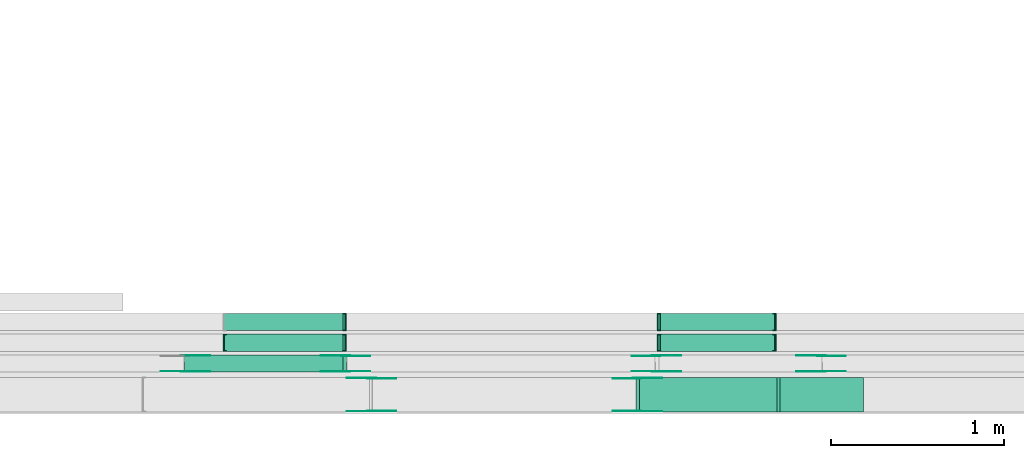
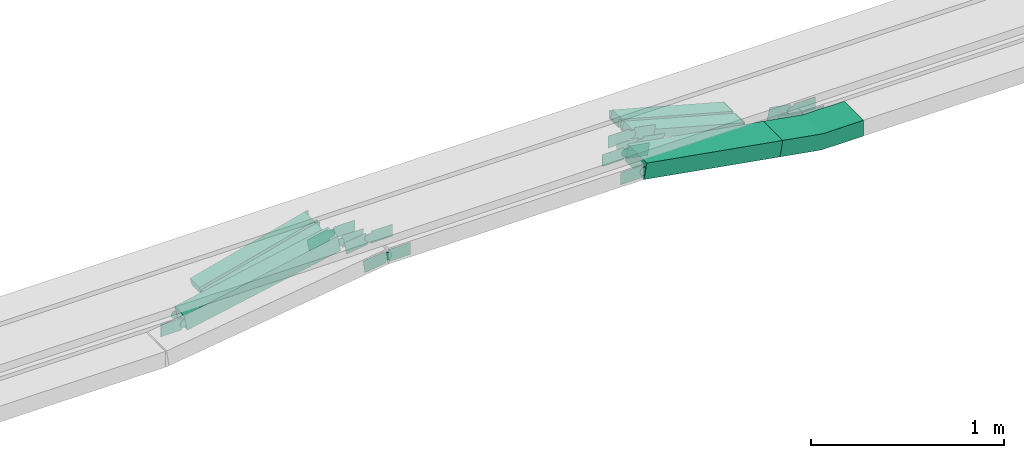
# One storey, part 8 of 31: 31 flow fittings, 6 flow segments.
"""IFC2X3 building model written with IfcOpenShell, lengths in millimetres."""

import ifcopenshell
import ifcopenshell.guid

model = None  # the IFC model being written
_history = None  # IfcOwnerHistory: only IFC2X3 demands one
_inside = {}  # id of a spatial element -> (the spatial element, [elements in it])
_under = {}  # id of a project, library or spatial element -> (it, [spatial elements below it])
_declared = {}  # id of a project -> (the project, [libraries it declares])
_typed = {}  # id of a type object -> (the type object, [elements of that type])
_made_of = {}  # id of a material, layer set ... -> (it, [elements and type objects made of it])


def new_model(schema):
    """Start an empty IFC model of exactly this schema.

    Asked for "IFC4X3", IfcOpenShell would pick the latest addendum, in which some entities
    have other attributes; the version numbers below select the first issue.
    IFC2X3 requires an IfcOwnerHistory on every rooted entity: one is made here for all.
    """
    global model, _history
    if schema == "IFC4X3":
        model = ifcopenshell.file(schema_version=(4, 3, 0, 0))
    else:
        model = ifcopenshell.file(schema=schema)
    _inside.clear()
    _under.clear()
    _declared.clear()
    _typed.clear()
    _made_of.clear()
    _history = None
    if model.schema == "IFC2X3":
        org = make("IfcOrganization", Name="unknown")
        user = make(
            "IfcPersonAndOrganization",
            ThePerson=make("IfcPerson", FamilyName="unknown"),
            TheOrganization=org,
        )
        app = make(
            "IfcApplication",
            ApplicationDeveloper=org,
            Version="unknown",
            ApplicationFullName="unknown",
            ApplicationIdentifier="unknown",
        )
        _history = make(
            "IfcOwnerHistory",
            OwningUser=user,
            OwningApplication=app,
            ChangeAction="ADDED",
            CreationDate=0,
        )
    return model


def make(cls, **values):
    """One entity of the class cls with the attributes given. An attribute that is None is left unset."""
    return model.create_entity(
        cls, **{name: value for name, value in values.items() if value is not None}
    )


def entity(cls, *values):
    """Any entity or typed value of the class cls, its attributes in the order of the schema. None: left unset."""
    e = model.create_entity(cls)
    for i, value in enumerate(values):
        if value is not None:
            e[i] = value
    return e


def rooted(cls, **values):
    """An entity with a GlobalId (a new one), such as an element, a storey or a relation."""
    return make(cls, GlobalId=ifcopenshell.guid.new(), OwnerHistory=_history, **values)


def si_unit(unit_type, name, prefix=None):
    """IfcSIUnit, for example si_unit("LENGTHUNIT", "METRE", prefix="MILLI")."""
    return make("IfcSIUnit", UnitType=unit_type, Prefix=prefix, Name=name)


def converted_unit(unit_type, name, factor, base, dimensions=None, offset=None):
    """IfcConversionBasedUnit, such as the inch: factor (a typed value) times the base unit."""
    return make(
        "IfcConversionBasedUnit"
        if offset is None
        else "IfcConversionBasedUnitWithOffset",
        ConversionOffset=offset,
        Dimensions=None
        if dimensions is None
        else entity("IfcDimensionalExponents", *dimensions),
        UnitType=unit_type,
        Name=name,
        ConversionFactor=make(
            "IfcMeasureWithUnit", ValueComponent=factor, UnitComponent=base
        ),
    )


def derived_unit(unit_type, elements):
    """IfcDerivedUnit: a product of units, each with its exponent."""
    return make(
        "IfcDerivedUnit",
        Elements=[
            make("IfcDerivedUnitElement", Unit=unit, Exponent=power)
            for unit, power in elements
        ],
        UnitType=unit_type,
    )


def assignment(units):
    """IfcUnitAssignment: the units of a project."""
    return None if units is None else make("IfcUnitAssignment", Units=units)


def point(xyz):
    """IfcCartesianPoint."""
    return None if xyz is None else make("IfcCartesianPoint", Coordinates=xyz)


def direction(xyz):
    """IfcDirection."""
    return None if xyz is None else make("IfcDirection", DirectionRatios=xyz)


def frame(location, z_axis=None, x_axis=None):
    """IfcAxis2Placement3D, a coordinate frame: its origin and axes. An axis left out is left unset."""
    return make(
        "IfcAxis2Placement3D",
        Location=point(location),
        Axis=direction(z_axis),
        RefDirection=direction(x_axis),
    )


def frame_2d(location, x_axis=None):
    """IfcAxis2Placement2D, a coordinate frame in the plane: its origin and x axis."""
    return make(
        "IfcAxis2Placement2D", Location=point(location), RefDirection=direction(x_axis)
    )


def origin():
    """The frame at (0, 0, 0) with its axes left unset."""
    return frame((0.0, 0.0, 0.0))


def origin_2d_with_axis():
    """The frame at (0, 0) in the plane with the x axis (1, 0) written out."""
    return frame_2d((0.0, 0.0), x_axis=(1.0, 0.0))


def place(relative_to, where):
    """IfcLocalPlacement: puts the frame where relative to a parent placement (None: the world)."""
    return make(
        "IfcLocalPlacement", PlacementRelTo=relative_to, RelativePlacement=where
    )


def context(
    kind, dimensions, precision=None, world=None, true_north=None, identifier=None
):
    """IfcGeometricRepresentationContext, for example the 3D "Model" context."""
    return make(
        "IfcGeometricRepresentationContext",
        ContextIdentifier=identifier,
        ContextType=kind,
        CoordinateSpaceDimension=dimensions,
        Precision=precision,
        WorldCoordinateSystem=world,
        TrueNorth=true_north,
    )


def subcontext(parent, identifier, kind, view, scale=None):
    """IfcGeometricRepresentationSubContext, for example "Body" below "Model"."""
    return make(
        "IfcGeometricRepresentationSubContext",
        ContextIdentifier=identifier,
        ContextType=kind,
        ParentContext=parent,
        TargetScale=scale,
        TargetView=view,
    )


def project(units=None, contexts=None):
    """IfcProject with its units and contexts."""
    return rooted(
        "IfcProject",
        Name="project",
        RepresentationContexts=contexts,
        UnitsInContext=assignment(units),
    )


def spatial(cls, under=None, at=None, **own):
    """A site, building, storey or space (cls), placed at a placement, below another one or the project."""
    s = rooted(cls, ObjectPlacement=at, **own)
    if under is not None:
        _under.setdefault(under.id(), (under, []))[1].append(s)
    return s


def polyline(points):
    """IfcPolyline through the points."""
    return make("IfcPolyline", Points=[point(p) for p in points])


def circle_curve(where, radius):
    """IfcCircle in the frame where."""
    return make("IfcCircle", Position=where, Radius=radius)


def parameter(value):
    """IfcParameterValue: where a trimmed curve begins or ends, as a parameter of its basis curve."""
    return model.create_entity("IfcParameterValue", value)


def trimmed(basis, trim1, trim2, sense, master):
    """IfcTrimmedCurve: the piece of a basis curve between two trims."""
    return make(
        "IfcTrimmedCurve",
        BasisCurve=basis,
        Trim1=trim1,
        Trim2=trim2,
        SenseAgreement=sense,
        MasterRepresentation=master,
    )


def segment(curve, same_sense, transition):
    """IfcCompositeCurveSegment."""
    return make(
        "IfcCompositeCurveSegment",
        Transition=transition,
        SameSense=same_sense,
        ParentCurve=curve,
    )


def composite_curve(segments, self_intersect=None):
    """IfcCompositeCurve: segments joined end to end."""
    return make("IfcCompositeCurve", Segments=segments, SelfIntersect=self_intersect)


def profile(cls, at=None, kind="AREA", **sizes):
    """A parametric profile (cls). Its sizes go by their IFC names, for example OverallWidth=200.0."""
    return make(cls, ProfileType=kind, Position=at, **sizes)


def rectangle(**sizes):
    """IfcRectangleProfileDef."""
    return profile("IfcRectangleProfileDef", **sizes)


def outline(outer, holes=None, kind="AREA"):
    """IfcArbitraryClosedProfileDef: a profile drawn as a closed curve; with holes, ...WithVoids."""
    if holes is None:
        return make("IfcArbitraryClosedProfileDef", ProfileType=kind, OuterCurve=outer)
    return make(
        "IfcArbitraryProfileDefWithVoids",
        ProfileType=kind,
        OuterCurve=outer,
        InnerCurves=holes,
    )


def extrude(swept, where, along, depth):
    """IfcExtrudedAreaSolid: the profile swept, set in the frame where, extruded along a direction by depth."""
    return make(
        "IfcExtrudedAreaSolid",
        SweptArea=swept,
        Position=where,
        ExtrudedDirection=direction(along),
        Depth=depth,
    )


def faces_of(points, faces, orient=None, outer=None):
    """IfcFace entities. A face is a list of loops; a loop is a list of indices into points, from 0.

    orient and outer hold one flag for each loop. By default every Orientation is true, the
    first loop of a face is its IfcFaceOuterBound and the others are IfcFaceBound.
    """
    made = []
    for i, loops in enumerate(faces):
        bounds = []
        for j, loop in enumerate(loops):
            is_outer = j == 0 if outer is None else outer[i][j]
            bounds.append(
                make(
                    "IfcFaceOuterBound" if is_outer else "IfcFaceBound",
                    Bound=make("IfcPolyLoop", Polygon=[points[k] for k in loop]),
                    Orientation=True if orient is None else orient[i][j],
                )
            )
        made.append(make("IfcFace", Bounds=bounds))
    return made


def faceted_brep(points, faces, orient=None, outer=None, voids=None):
    """IfcFacetedBrep: a solid bounded by flat faces; with voids (closed shells), ...WithVoids."""
    shared = [point(p) for p in points]
    hull = make("IfcClosedShell", CfsFaces=faces_of(shared, faces, orient, outer))
    if voids is None:
        return make("IfcFacetedBrep", Outer=hull)
    return make(
        "IfcFacetedBrepWithVoids",
        Outer=hull,
        Voids=[
            make(cls, CfsFaces=faces_of(shared, fs, o, b)) for cls, fs, o, b in voids
        ],
    )


def shape(context_of_items, identifier, shape_type, items):
    """IfcShapeRepresentation: the items that make up one representation, for example the "Body"."""
    return make(
        "IfcShapeRepresentation",
        ContextOfItems=context_of_items,
        RepresentationIdentifier=identifier,
        RepresentationType=shape_type,
        Items=items,
    )


def source(mapping_origin, context_of_items, identifier, shape_type, items):
    """IfcRepresentationMap: a shape defined once, which mapped items show again and again."""
    return make(
        "IfcRepresentationMap",
        MappingOrigin=mapping_origin,
        MappedRepresentation=shape(context_of_items, identifier, shape_type, items),
    )


def transform(
    local_origin,
    x_axis=None,
    y_axis=None,
    z_axis=None,
    scale=None,
    scale2=None,
    scale3=None,
    uniform=True,
):
    """IfcCartesianTransformationOperator3D, or its non-uniform kind. x_axis, y_axis, z_axis: its Axis1, 2, 3."""
    if uniform:
        return make(
            "IfcCartesianTransformationOperator3D",
            Axis1=direction(x_axis),
            Axis2=direction(y_axis),
            LocalOrigin=point(local_origin),
            Scale=scale,
            Axis3=direction(z_axis),
        )
    return make(
        "IfcCartesianTransformationOperator3DnonUniform",
        Axis1=direction(x_axis),
        Axis2=direction(y_axis),
        LocalOrigin=point(local_origin),
        Scale=scale,
        Axis3=direction(z_axis),
        Scale2=scale2,
        Scale3=scale3,
    )


def mapped(mapping_source, mapping_target):
    """IfcMappedItem: shows the shape of a source again, moved by a transform."""
    return make(
        "IfcMappedItem", MappingSource=mapping_source, MappingTarget=mapping_target
    )


def material(Name=None, Category=None):
    """IfcMaterial."""
    return make("IfcMaterial", Name=Name, Category=Category)


def made_of(thing, what):
    """Note that an element or type object is made of a material, layer set ...; save() writes the relation."""
    if what is not None:
        _made_of.setdefault(what.id(), (what, []))[1].append(thing)
    return thing


def type_object(cls, material=None, **own):
    """A type object (cls), such as IfcWallType, which elements share."""
    return made_of(rooted(cls, **own), material)


def type_shapes(of_type, sources):
    """Give a type object the sources (RepresentationMaps) that its elements show as mapped items."""
    of_type.RepresentationMaps = sources


def element(
    cls,
    number,
    at=None,
    inside=None,
    cuts=None,
    type_object=None,
    material=None,
    context=None,
    identifier="Body",
    shape_type=None,
    held_by="IfcProductDefinitionShape",
    body=None,
    shapes=None,
    **own,
):
    """One element of the class cls, such as IfcWall. Its Tag is "e" and its number.

    at: its placement. inside: the storey or other place that contains it. cuts: it is an
    opening in that element (IfcRelVoidsElement). A single representation is given by context,
    identifier, shape_type and body (its items); several are given by shapes. held_by: the class
    of the entity that holds the representations. save() writes the other relations.
    """
    e = rooted(cls, Tag="e%d" % number, ObjectPlacement=at, **own)
    if body is not None:
        shapes = [shape(context, identifier, shape_type, body)]
    if shapes is not None:
        e.Representation = make(held_by, Representations=shapes)
    if inside is not None:
        _inside.setdefault(inside.id(), (inside, []))[1].append(e)
    if cuts is not None:
        rooted(
            "IfcRelVoidsElement", RelatingBuildingElement=cuts, RelatedOpeningElement=e
        )
    if type_object is not None:
        _typed.setdefault(type_object.id(), (type_object, []))[1].append(e)
    return made_of(e, material)


def aggregate(whole, parts):
    """IfcRelAggregates: a whole, such as a stair, and the parts it consists of."""
    return rooted("IfcRelAggregates", RelatingObject=whole, RelatedObjects=parts)


def save(model, path):
    """Write the relations noted so far, then the file.

    IfcRelAggregates (storeys below a building ...), IfcRelContainedInSpatialStructure (elements
    in a storey), IfcRelDefinesByType, IfcRelAssociatesMaterial and IfcRelDeclares: one each for
    every whole, place, type object, material and project.
    """
    for whole, parts in _under.values():
        aggregate(whole, parts)
    for where, things in _inside.values():
        rooted(
            "IfcRelContainedInSpatialStructure",
            RelatedElements=things,
            RelatingStructure=where,
        )
    for kind, things in _typed.values():
        rooted("IfcRelDefinesByType", RelatedObjects=things, RelatingType=kind)
    for what, things in _made_of.values():
        rooted("IfcRelAssociatesMaterial", RelatedObjects=things, RelatingMaterial=what)
    for by, libraries in _declared.values():
        rooted("IfcRelDeclares", RelatingContext=by, RelatedDefinitions=libraries)
    model.write(path)


model = new_model("IFC2X3")

# Units and contexts
model_context = context("Model", 3, precision=0.01, world=origin(), true_north=direction((6.12303176911189e-17, 1.0)))
body_context = subcontext(model_context, "Body", "Model", "MODEL_VIEW")
ifc_project = project(units=[si_unit("LENGTHUNIT", "METRE", prefix="MILLI"), si_unit("AREAUNIT", "SQUARE_METRE"), si_unit("VOLUMEUNIT", "CUBIC_METRE"), converted_unit("PLANEANGLEUNIT", "DEGREE", entity("IfcRatioMeasure", 0.0174532925199433), si_unit("PLANEANGLEUNIT", "RADIAN"), dimensions=[0, 0, 0, 0, 0, 0, 0]), si_unit("MASSUNIT", "GRAM", prefix="KILO"), derived_unit("MASSDENSITYUNIT", [(si_unit("MASSUNIT", "GRAM", prefix="KILO"), 1), (si_unit("LENGTHUNIT", "METRE"), -3)]), derived_unit("MOMENTOFINERTIAUNIT", [(si_unit("LENGTHUNIT", "METRE"), 4)]), si_unit("TIMEUNIT", "SECOND"), si_unit("FREQUENCYUNIT", "HERTZ"), si_unit("THERMODYNAMICTEMPERATUREUNIT", "DEGREE_CELSIUS"), derived_unit("THERMALTRANSMITTANCEUNIT", [(si_unit("MASSUNIT", "GRAM", prefix="KILO"), 1), (si_unit("THERMODYNAMICTEMPERATUREUNIT", "KELVIN"), -1), (si_unit("TIMEUNIT", "SECOND"), -3)]), derived_unit("VOLUMETRICFLOWRATEUNIT", [(si_unit("LENGTHUNIT", "METRE"), 3), (si_unit("TIMEUNIT", "SECOND"), -1)]), derived_unit("MASSFLOWRATEUNIT", [(si_unit("MASSUNIT", "GRAM", prefix="KILO"), 1), (si_unit("TIMEUNIT", "SECOND"), -1)]), derived_unit("ROTATIONALFREQUENCYUNIT", [(si_unit("TIMEUNIT", "SECOND"), -1)]), si_unit("ELECTRICCURRENTUNIT", "AMPERE"), si_unit("ELECTRICVOLTAGEUNIT", "VOLT"), si_unit("POWERUNIT", "WATT"), si_unit("FORCEUNIT", "NEWTON", prefix="KILO"), si_unit("ILLUMINANCEUNIT", "LUX"), si_unit("LUMINOUSFLUXUNIT", "LUMEN"), si_unit("LUMINOUSINTENSITYUNIT", "CANDELA"), derived_unit("USERDEFINED", [(si_unit("MASSUNIT", "GRAM", prefix="KILO"), -1), (si_unit("LENGTHUNIT", "METRE"), -2), (si_unit("TIMEUNIT", "SECOND"), 3), (si_unit("LUMINOUSFLUXUNIT", "LUMEN"), 1)]), derived_unit("LINEARVELOCITYUNIT", [(si_unit("LENGTHUNIT", "METRE"), 1), (si_unit("TIMEUNIT", "SECOND"), -1)]), si_unit("PRESSUREUNIT", "PASCAL"), derived_unit("USERDEFINED", [(si_unit("LENGTHUNIT", "METRE"), -2), (si_unit("MASSUNIT", "GRAM", prefix="KILO"), 1), (si_unit("TIMEUNIT", "SECOND"), -2)]), derived_unit("LINEARFORCEUNIT", [(si_unit("MASSUNIT", "GRAM", prefix="KILO"), 1), (si_unit("LENGTHUNIT", "METRE"), 1), (si_unit("TIMEUNIT", "SECOND"), -2), (si_unit("LENGTHUNIT", "METRE"), -1)]), derived_unit("PLANARFORCEUNIT", [(si_unit("MASSUNIT", "GRAM", prefix="KILO"), 1), (si_unit("LENGTHUNIT", "METRE"), 1), (si_unit("TIMEUNIT", "SECOND"), -2), (si_unit("LENGTHUNIT", "METRE"), -2)])], contexts=[model_context])

# Site, building, storey
site_placement = place(None, frame((0.0, -0.00077364408347762, 0.0)))
site = spatial("IfcSite", under=ifc_project, at=site_placement, CompositionType="ELEMENT")
building_placement = place(site_placement, origin())
building = spatial("IfcBuilding", under=site, at=building_placement, CompositionType="ELEMENT")
storey_placement = place(building_placement, frame((0.0, 0.0, 15900.0)))
storey = spatial("IfcBuildingStorey", under=building, at=storey_placement, CompositionType="ELEMENT", Elevation=15900.0)

# Flow segments
cable_carrier_segment_type = type_object("IfcCableCarrierSegmentType", PredefinedType="CABLETRAYSEGMENT")
flow_segment_1_placement = place(storey_placement, frame((23818.3797769775, 8695.50215480076, 2502.48100991724)))
element("IfcFlowSegment", 1, at=flow_segment_1_placement, inside=storey, type_object=cable_carrier_segment_type, context=body_context, shape_type="SweptSolid", body=[
    extrude(rectangle(XDim=50.0000000000003, YDim=99.9999999999989, at=origin_2d_with_axis()), frame((6.37700798333242, 50.0, 24.172996694259), z_axis=(0.966919867770266, 0.0, 0.255080319333208), x_axis=(-0.255080319333208, 0.0, 0.966919867770266)), (0.0, 0.0, 1.0), 712.293238662787),
])
flow_segment_2_placement = place(storey_placement, frame((26335.7437232467, 8695.50215480076, 2502.66588279373)))
element("IfcFlowSegment", 2, at=flow_segment_2_placement, inside=storey, type_object=cable_carrier_segment_type, context=body_context, shape_type="SweptSolid", body=[
    extrude(rectangle(XDim=50.0000000000012, YDim=99.9999999999989, at=frame_2d((0.0, 2.08899564313469e-12), x_axis=(0.0, 1.0))), frame((6.60618807540411, 50.0, 205.556862010423), z_axis=(0.964454896083655, 0.0, -0.264247523016331), x_axis=(0.0, 1.0, 0.0)), (0.0, 0.0, 1.0), 686.649727260089),
])
flow_segment_3_placement = place(storey_placement, frame((23587.5004149848, 8454.96624585791, 2502.1837733382)))
element("IfcFlowSegment", 3, at=flow_segment_3_placement, inside=storey, type_object=cable_carrier_segment_type, context=body_context, shape_type="SweptSolid", body=[
    extrude(rectangle(XDim=100.000000000002, YDim=100.000000000001, at=frame_2d((0.0, 1.08357767203415e-12), x_axis=(1.0, 0.0))), frame((9.7322474506551, 50.0, 49.0436882744265), z_axis=(0.980873765488559, 0.0, 0.194644949013056), x_axis=(-0.194644949013056, 0.0, 0.980873765488559)), (0.0, 0.0, 1.0), 937.836186864069),
])
flow_segment_4_placement = place(storey_placement, frame((23818.3797769775, 8575.50215480076, 2502.48100991724)))
element("IfcFlowSegment", 4, at=flow_segment_4_placement, inside=storey, type_object=cable_carrier_segment_type, context=body_context, shape_type="SweptSolid", body=[
    extrude(rectangle(XDim=50.0000000000003, YDim=100.000000000001, at=origin_2d_with_axis()), frame((6.37700798333242, 50.0, 24.172996694259), z_axis=(0.966919867770266, 0.0, 0.255080319333208), x_axis=(-0.255080319333208, 0.0, 0.966919867770266)), (0.0, 0.0, 1.0), 712.293238662787),
])
flow_segment_5_placement = place(storey_placement, frame((26335.7437232467, 8575.50215480076, 2502.66588279373)))
element("IfcFlowSegment", 5, at=flow_segment_5_placement, inside=storey, type_object=cable_carrier_segment_type, context=body_context, shape_type="SweptSolid", body=[
    extrude(rectangle(XDim=50.0000000000012, YDim=100.000000000001, at=frame_2d((0.0, 2.08899564313469e-12), x_axis=(0.0, 1.0))), frame((6.60618807540411, 50.0, 205.556862010419), z_axis=(0.964454896083655, 0.0, -0.264247523016331), x_axis=(0.0, 1.0, 0.0)), (0.0, 0.0, 1.0), 686.649727260089),
])
flow_segment_6_placement = place(storey_placement, frame((26209.4701647969, 8224.96624585793, 2543.15198452124)))
element("IfcFlowSegment", 6, at=flow_segment_6_placement, inside=storey, type_object=cable_carrier_segment_type, context=body_context, shape_type="SweptSolid", body=[
    extrude(rectangle(XDim=100.000000000002, YDim=200.0, at=origin_2d_with_axis()), frame((8.56658973083937, 100.0, 190.878206533637), z_axis=(0.985213386101388, 0.0, -0.171331794616871), x_axis=(0.171331794616871, 0.0, 0.985213386101388)), (0.0, 0.0, 1.0), 826.568924613313),
])

# Flow fittings
ifc_material_1 = material()
cable_carrier_fitting_type_1 = type_object("IfcCableCarrierFittingType", PredefinedType="NOTDEFINED", material=ifc_material_1)
shared_shape_1 = source(origin(), body_context, "Body", "Brep", [
    faceted_brep([(-6.4842580400182, 25.0, 50.0), (-6.4842580400182, 25.0, -50.0), (-6.48425804001836, -25.0, -50.0), (-6.48425804001836, -25.0, -47.4600000101565), (-6.48425804001821, 22.46000001016, -47.4600000101565), (-6.48425804001821, 22.46000001016, 47.4600000101635), (-6.48425804001836, -25.0, 47.4600000101635), (-6.48425804001836, -25.0, 50.0), (-0.107250056687216, 25.8270033057431, 50.0), (12.6467659099747, -22.5189900827698, 50.0), (12.6467659099747, -22.5189900827698, 47.4600000101635), (0.540653951827591, 23.3710268514305, 47.4600000101635), (0.54065395182759, 23.3710268514305, -47.4600000101565), (12.6467659099747, -22.5189900827698, -47.4600000101565), (12.6467659099747, -22.5189900827698, -50.0), (-0.107250056687218, 25.8270033057431, -50.0), (-3.24212902000882, 25.0, 50.0), (-3.24212902000888, 25.0, -50.0), (3.24212902000979, -25.0, -50.0), (3.24212902000979, -25.0, -47.4600000101565), (-2.91272871289353, 22.46000001016, -47.4600000101565), (-2.91272871289353, 22.46000001016, 47.4600000101635), (3.24212902000979, -25.0, 47.4600000101635), (3.24212902000979, -25.0, 50.0)], [[[0, 1, 2, 3, 4, 5, 6, 7]], [[8, 9, 10, 11, 12, 13, 14, 15]], [[1, 0, 16, 17]], [[2, 1, 17, 15, 14, 18]], [[3, 2, 18, 19]], [[4, 3, 19, 13, 12, 20]], [[5, 4, 20, 21]], [[6, 5, 21, 11, 10, 22]], [[7, 6, 22, 23]], [[0, 7, 23, 9, 8, 16]], [[17, 16, 8, 15]], [[19, 18, 14, 13]], [[21, 20, 12, 11]], [[23, 22, 10, 9]]]),
])
type_shapes(cable_carrier_fitting_type_1, [shared_shape_1])
for number, where, z_axis, x_axis in (
    (7, (24519.757027029, 8745.50215480077, 2710.0), (0.0, -1.0, 0.0), (-1.0, 0.0, 0.0)),
    (8, (24519.757027029, 8625.50215480077, 2710.0), (0.0, -1.0, 0.0), (-1.0, 0.0, 0.0)),
    (9, (23818.4870270342, 8625.50215480077, 2525.0), (0.0, 1.0, 0.0), (-0.966919867770264, 0.0, -0.255080319333216)),
):
    element("IfcFlowFitting", number, at=place(storey_placement, frame(where, z_axis=z_axis, x_axis=x_axis)), inside=storey, type_object=cable_carrier_fitting_type_1, material=ifc_material_1, context=body_context, shape_type="MappedRepresentation", body=[
        mapped(shared_shape_1, transform((0.0, 0.0, 0.0), scale=1.0)),
    ])
cable_carrier_fitting_type_2 = type_object("IfcCableCarrierFittingType", PredefinedType="NOTDEFINED", material=ifc_material_1)
shared_shape_2 = source(origin(), body_context, "Body", "Brep", [
    faceted_brep([(-6.7257213067909, 25.0, 50.0), (-6.7257213067909, 25.0, -50.0), (-6.72572130679106, -25.0, -50.0), (-6.72572130679106, -25.0, -47.4600000101565), (-6.7257213067909, 22.46000001016, -47.4600000101565), (-6.7257213067909, 22.46000001016, 47.4600000101635), (-6.72572130679106, -25.0, 47.4600000101635), (-6.72572130679106, -25.0, 50.0), (-0.119533231380651, 25.8886275979087, 50.0), (13.0928429194398, -22.334117206273, 50.0), (13.0928429194398, -22.334117206273, 47.4600000101635), (0.551655474396273, 23.4389121716551, 47.4600000101635), (0.551655474396268, 23.4389121716552, -47.4600000101565), (13.0928429194398, -22.334117206273, -47.4600000101565), (13.0928429194398, -22.334117206273, -50.0), (-0.119533231380649, 25.8886275979087, -50.0), (-3.36286065339516, 25.0, 50.0), (-3.36286065339522, 25.0, -50.0), (3.36286065339612, -25.0, -50.0), (3.36286065339612, -25.0, -47.4600000101565), (-3.02119401237689, 22.46000001016, -47.4600000101565), (-3.02119401237689, 22.46000001016, 47.4600000101635), (3.36286065339612, -25.0, 47.4600000101635), (3.36286065339612, -25.0, 50.0)], [[[0, 1, 2, 3, 4, 5, 6, 7]], [[8, 9, 10, 11, 12, 13, 14, 15]], [[1, 0, 16, 17]], [[2, 1, 17, 15, 14, 18]], [[3, 2, 18, 19]], [[4, 3, 19, 13, 12, 20]], [[5, 4, 20, 21]], [[6, 5, 21, 11, 10, 22]], [[7, 6, 22, 23]], [[0, 7, 23, 9, 8, 16]], [[17, 16, 8, 15]], [[19, 18, 14, 13]], [[21, 20, 12, 11]], [[23, 22, 10, 9]]]),
])
type_shapes(cable_carrier_fitting_type_2, [shared_shape_2])
for number, where, z_axis, x_axis in (
    (10, (26335.8632564781, 8745.50215480077, 2710.0), (0.0, 1.0, 0.0), (1.0, 0.0, 0.0)),
    (11, (26335.8632564781, 8625.50215480077, 2710.0), (0.0, 1.0, 0.0), (1.0, 0.0, 0.0)),
    (12, (27011.0792575166, 8745.50215480077, 2525.0), (0.0, -1.0, 0.0), (0.964454896083642, 0.0, -0.264247523016377)),
    (13, (27011.0792575166, 8625.50215480077, 2525.0), (0.0, -1.0, 0.0), (0.964454896083642, 0.0, -0.264247523016377)),
):
    element("IfcFlowFitting", number, at=place(storey_placement, frame(where, z_axis=z_axis, x_axis=x_axis)), inside=storey, type_object=cable_carrier_fitting_type_2, material=ifc_material_1, context=body_context, shape_type="MappedRepresentation", body=[
        mapped(shared_shape_2, transform((0.0, 0.0, 0.0), scale=1.0)),
    ])
cable_carrier_fitting_type_3 = type_object("IfcCableCarrierFittingType", Name="470_DKC_S5_CS 90 internal vertical angle:-", PredefinedType="NOTDEFINED", material=ifc_material_1)
shared_shape_3 = source(origin(), body_context, "Body", "SweptSolid", [
    extrude(outline(composite_curve([segment(polyline([(-246.579159307226, -61.2131112799003), (-13.2724188832449, -61.2131112799003)]), True, "CONTINUOUS"), segment(trimmed(circle_curve(frame_2d((-13.2724188832452, 153.786888720099), x_axis=(0.0, -1.0)), 214.999999999999), [parameter(0.0)], [parameter(9.86526143430176)], True, "PARAMETER"), True, "CONTINUOUS"), segment(polyline([(23.5639169593865, -58.0339892916979), (253.420840692774, -18.0611267586402)]), True, "CONTINUOUS"), segment(polyline([(253.420840692774, -18.0611267586403), (236.287661231085, 80.4602118514985)]), True, "CONTINUOUS"), segment(polyline([(236.287661231085, 80.4602118514985), (6.43073749769714, 40.4873493184407)]), True, "CONTINUOUS"), segment(trimmed(circle_curve(frame_2d((-13.2724188832452, 153.786888720099), x_axis=(0.0, -1.0)), 114.999999999999), [parameter(0.0)], [parameter(9.86526143430176)], True, "PARAMETER"), False, "CONTINUOUS"), segment(polyline([(-13.2724188832449, 38.7868887200999), (-246.579159307226, 38.7868887201)]), True, "CONTINUOUS"), segment(polyline([(-246.579159307226, 38.7868887201), (-246.579159307226, -61.2131112799003)]), True, "CONTINUOUS")], self_intersect=False)), frame((-0.967736008761854, 11.213111279893, -100.0)), (0.0, 0.0, 1.0), 200.0),
])
type_shapes(cable_carrier_fitting_type_3, [shared_shape_3])
flow_fitting_placement = place(storey_placement, frame((27276.2700385454, 8324.96624585793, 2550.0), z_axis=(0.0, 1.0, 0.0), x_axis=(-1.0, 0.0, 0.0)))
element("IfcFlowFitting", 14, at=flow_fitting_placement, inside=storey, type_object=cable_carrier_fitting_type_3, material=ifc_material_1, Name="470_DKC_S5_CS 90 internal vertical angle:-", ObjectType="470_DKC_S5_CS 90 internal vertical angle:-", context=body_context, shape_type="MappedRepresentation", body=[
    mapped(shared_shape_3, transform((0.0, 0.0, 0.0), scale=1.0)),
])
ifc_material_2 = material(Name="G")
cable_carrier_fitting_type_4 = type_object("IfcCableCarrierFittingType", PredefinedType="NOTDEFINED", material=ifc_material_2)
shared_shape_4 = source(origin(), body_context, "Body", "SweptSolid", [
    extrude(outline(composite_curve([segment(trimmed(circle_curve(frame_2d((-41.4651162790697, 0.0), x_axis=(1.0, 0.0)), 25.0), [parameter(90.0000000000007)], [parameter(270.0)], True, "PARAMETER"), True, "CONTINUOUS"), segment(polyline([(-41.4651162790697, -25.0), (-29.9651162790697, -25.0)]), True, "CONTINUOUS"), segment(polyline([(-29.9651162790697, -25.0), (-28.1046511627907, -38.5)]), True, "CONTINUOUS"), segment(polyline([(-28.1046511627907, -38.5), (99.5348837209303, -38.5)]), True, "CONTINUOUS"), segment(polyline([(99.5348837209303, -38.5), (99.5348837209303, 38.5)]), True, "CONTINUOUS"), segment(polyline([(99.5348837209303, 38.5), (-28.1046511627907, 38.5)]), True, "CONTINUOUS"), segment(polyline([(-28.1046511627907, 38.5), (-29.9651162790697, 25.0)]), True, "CONTINUOUS"), segment(polyline([(-29.9651162790697, 25.0), (-41.46511627907, 25.0)]), True, "CONTINUOUS")], self_intersect=False)), frame((41.4651162790697, 0.0, 0.0), z_axis=(0.0, 0.0, -1.0), x_axis=(1.0, 0.0, 0.0)), (0.0, 0.0, -1.0), 2.0),
])
type_shapes(cable_carrier_fitting_type_4, [shared_shape_4])
for number, where, z_axis, x_axis in (
    (15, (24523.3171184433, 8459.50624584775, 2735.0), (0.0, -1.0, 0.0), (-0.98087376548856, 0.0, -0.194644949013054)),
    (16, (26322.0471184484, 8550.42624586807, 2735.0), (0.0, 1.0, 0.0), (0.981897917883986, 0.0, -0.189410873117392)),
    (17, (23591.0471184485, 8459.50624584776, 2550.0), (0.0, -1.0, 0.0), (0.98087376548856, 0.0, 0.194644949013054)),
    (18, (27281.0792575167, 8550.42624586807, 2550.0), (0.0, 1.0, 0.0), (-0.981897917883986, 0.0, 0.189410873117392)),
    (19, (24673.7300385556, 8229.50624584777, 2735.0), (0.0, -1.0, 0.0), (-0.990375964698788, 0.0, -0.138403210031213)),
    (20, (26212.4600385607, 8420.42624586809, 2735.0), (0.0, 1.0, 0.0), (0.985213386101383, 0.0, -0.171331794616902)),
):
    element("IfcFlowFitting", number, at=place(storey_placement, frame(where, z_axis=z_axis, x_axis=x_axis)), inside=storey, type_object=cable_carrier_fitting_type_4, material=ifc_material_2, context=body_context, shape_type="MappedRepresentation", body=[
        mapped(shared_shape_4, transform((0.0, 0.0, 0.0), scale=1.0)),
    ])
cable_carrier_fitting_type_5 = type_object("IfcCableCarrierFittingType", PredefinedType="NOTDEFINED", material=ifc_material_2)
shared_shape_5 = source(origin(), body_context, "Body", "SweptSolid", [
    extrude(outline(composite_curve([segment(trimmed(circle_curve(frame_2d((-41.4651162790697, 0.0), x_axis=(1.0, 0.0)), 25.0), [parameter(90.0000000000007)], [parameter(270.0)], True, "PARAMETER"), True, "CONTINUOUS"), segment(polyline([(-41.4651162790697, -25.0), (-29.9651162790697, -25.0)]), True, "CONTINUOUS"), segment(polyline([(-29.9651162790697, -25.0), (-28.1046511627907, -38.5)]), True, "CONTINUOUS"), segment(polyline([(-28.1046511627907, -38.5), (99.5348837209303, -38.5)]), True, "CONTINUOUS"), segment(polyline([(99.5348837209303, -38.5), (99.5348837209303, 38.5)]), True, "CONTINUOUS"), segment(polyline([(99.5348837209303, 38.5), (-28.1046511627907, 38.5)]), True, "CONTINUOUS"), segment(polyline([(-28.1046511627907, 38.5), (-29.9651162790697, 25.0)]), True, "CONTINUOUS"), segment(polyline([(-29.9651162790697, 25.0), (-41.46511627907, 25.0)]), True, "CONTINUOUS")], self_intersect=False)), frame((41.4651162790697, 0.0, 0.0)), (0.0, 0.0, 1.0), 2.0),
])
type_shapes(cable_carrier_fitting_type_5, [shared_shape_5])
for number, where, z_axis, x_axis in (
    (21, (24523.3171184433, 8550.42624586807, 2735.0), (0.0, 1.0, 0.0), (-0.98087376548856, 0.0, -0.194644949013054)),
    (22, (26322.0471184484, 8459.50624584775, 2735.0), (0.0, -1.0, 0.0), (0.981897917883986, 0.0, -0.189410873117392)),
    (23, (23591.0471184485, 8550.42624586808, 2550.0), (0.0, 1.0, 0.0), (0.98087376548856, 0.0, 0.194644949013054)),
    (24, (27281.0792575167, 8459.50624584775, 2550.0), (0.0, -1.0, 0.0), (-0.981897917883986, 0.0, 0.189410873117392)),
    (25, (24673.7300385556, 8420.42624586809, 2735.0), (0.0, 1.0, 0.0), (-0.990375964698788, 0.0, -0.138403210031213)),
    (26, (26212.4600385607, 8229.50624584777, 2735.0), (0.0, -1.0, 0.0), (0.985213386101383, 0.0, -0.171331794616902)),
):
    element("IfcFlowFitting", number, at=place(storey_placement, frame(where, z_axis=z_axis, x_axis=x_axis)), inside=storey, type_object=cable_carrier_fitting_type_5, material=ifc_material_2, context=body_context, shape_type="MappedRepresentation", body=[
        mapped(shared_shape_5, transform((0.0, 0.0, 0.0), scale=1.0)),
    ])
cable_carrier_fitting_type_6 = type_object("IfcCableCarrierFittingType", PredefinedType="NOTDEFINED", material=ifc_material_2)
shared_shape_6 = source(origin(), body_context, "Body", "SweptSolid", [
    extrude(outline(composite_curve([segment(trimmed(circle_curve(frame_2d((-41.4651162790697, 0.0), x_axis=(1.0, 0.0)), 25.0), [parameter(90.0000000000007)], [parameter(270.0)], True, "PARAMETER"), True, "CONTINUOUS"), segment(polyline([(-41.4651162790697, -25.0), (-29.9651162790697, -25.0)]), True, "CONTINUOUS"), segment(polyline([(-29.9651162790697, -25.0), (-28.1046511627907, -38.5)]), True, "CONTINUOUS"), segment(polyline([(-28.1046511627907, -38.5), (99.5348837209303, -38.5)]), True, "CONTINUOUS"), segment(polyline([(99.5348837209303, -38.5), (99.5348837209303, 38.5)]), True, "CONTINUOUS"), segment(polyline([(99.5348837209303, 38.5), (-28.1046511627907, 38.5)]), True, "CONTINUOUS"), segment(polyline([(-28.1046511627907, 38.5), (-29.9651162790697, 25.0)]), True, "CONTINUOUS"), segment(polyline([(-29.9651162790697, 25.0), (-41.46511627907, 25.0)]), True, "CONTINUOUS")], self_intersect=False)), frame((41.4651162790697, 0.0, 0.0), z_axis=(0.0, 0.0, -1.0), x_axis=(1.0, 0.0, 0.0)), (0.0, 0.0, -1.0), 2.0),
])
type_shapes(cable_carrier_fitting_type_6, [shared_shape_6])
for number, where, z_axis, x_axis in (
    (27, (24523.3171184433, 8548.42624586807, 2735.0), (0.0, 1.0, 0.0), (1.0, 0.0, 0.0)),
    (28, (26322.0471184484, 8461.50624584775, 2735.0), (0.0, -1.0, 0.0), (-1.0, 0.0, 0.0)),
    (29, (27281.0792575167, 8461.50624584775, 2550.0), (0.0, -1.0, 0.0), (1.0, 0.0, 0.0)),
    (30, (24673.7300385555, 8418.42624586809, 2735.0), (0.0, 1.0, 0.0), (1.0, 0.0, 0.0)),
    (31, (26212.4600385607, 8231.50624584777, 2735.0), (0.0, -1.0, 0.0), (-1.0, 0.0, 0.0)),
):
    element("IfcFlowFitting", number, at=place(storey_placement, frame(where, z_axis=z_axis, x_axis=x_axis)), inside=storey, type_object=cable_carrier_fitting_type_6, material=ifc_material_2, context=body_context, shape_type="MappedRepresentation", body=[
        mapped(shared_shape_6, transform((0.0, 0.0, 0.0), scale=1.0)),
    ])
cable_carrier_fitting_type_7 = type_object("IfcCableCarrierFittingType", PredefinedType="NOTDEFINED", material=ifc_material_2)
shared_shape_7 = source(origin(), body_context, "Body", "SweptSolid", [
    extrude(outline(composite_curve([segment(trimmed(circle_curve(frame_2d((-41.4651162790697, 0.0), x_axis=(1.0, 0.0)), 25.0), [parameter(90.0000000000007)], [parameter(270.0)], True, "PARAMETER"), True, "CONTINUOUS"), segment(polyline([(-41.4651162790697, -25.0), (-29.9651162790697, -25.0)]), True, "CONTINUOUS"), segment(polyline([(-29.9651162790697, -25.0), (-28.1046511627907, -38.5)]), True, "CONTINUOUS"), segment(polyline([(-28.1046511627907, -38.5), (99.5348837209303, -38.5)]), True, "CONTINUOUS"), segment(polyline([(99.5348837209303, -38.5), (99.5348837209303, 38.5)]), True, "CONTINUOUS"), segment(polyline([(99.5348837209303, 38.5), (-28.1046511627907, 38.5)]), True, "CONTINUOUS"), segment(polyline([(-28.1046511627907, 38.5), (-29.9651162790697, 25.0)]), True, "CONTINUOUS"), segment(polyline([(-29.9651162790697, 25.0), (-41.46511627907, 25.0)]), True, "CONTINUOUS")], self_intersect=False)), frame((41.4651162790697, 0.0, 0.0)), (0.0, 0.0, 1.0), 2.0),
])
type_shapes(cable_carrier_fitting_type_7, [shared_shape_7])
for number, where, z_axis, x_axis in (
    (32, (24523.3171184433, 8461.50624584775, 2735.0), (0.0, -1.0, 0.0), (1.0, 0.0, 0.0)),
    (33, (26322.0471184484, 8548.42624586807, 2735.0), (0.0, 1.0, 0.0), (-1.0, 0.0, 0.0)),
    (34, (23591.0471184485, 8461.50624584776, 2550.0), (0.0, -1.0, 0.0), (-1.0, 0.0, 0.0)),
    (35, (27281.0792575167, 8548.42624586807, 2550.0), (0.0, 1.0, 0.0), (1.0, 0.0, 0.0)),
    (36, (24673.7300385555, 8231.50624584777, 2735.0), (0.0, -1.0, 0.0), (1.0, 0.0, 0.0)),
    (37, (26212.4600385607, 8418.42624586809, 2735.0), (0.0, 1.0, 0.0), (-1.0, 0.0, 0.0)),
):
    element("IfcFlowFitting", number, at=place(storey_placement, frame(where, z_axis=z_axis, x_axis=x_axis)), inside=storey, type_object=cable_carrier_fitting_type_7, material=ifc_material_2, context=body_context, shape_type="MappedRepresentation", body=[
        mapped(shared_shape_7, transform((0.0, 0.0, 0.0), scale=1.0)),
    ])

save(model, "model.ifc")
